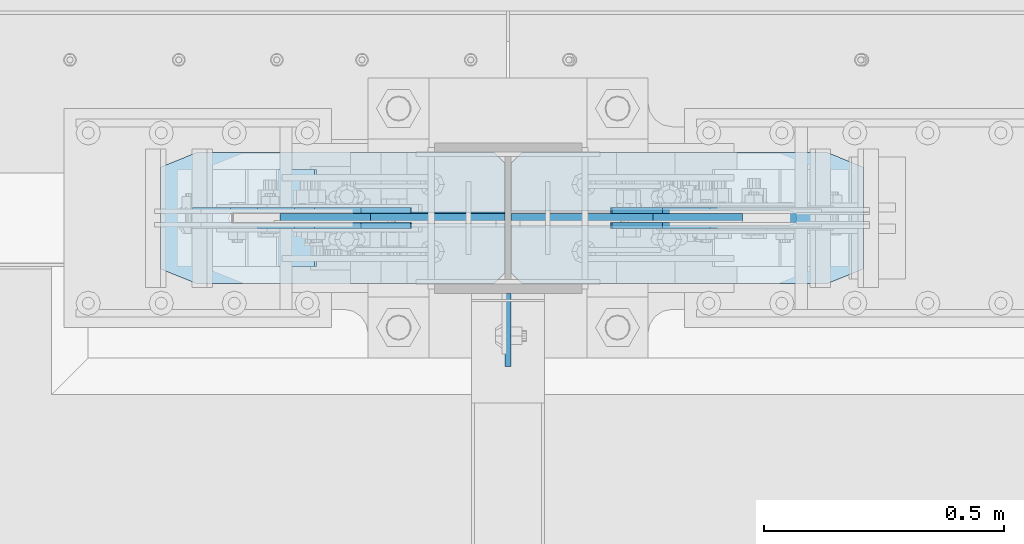
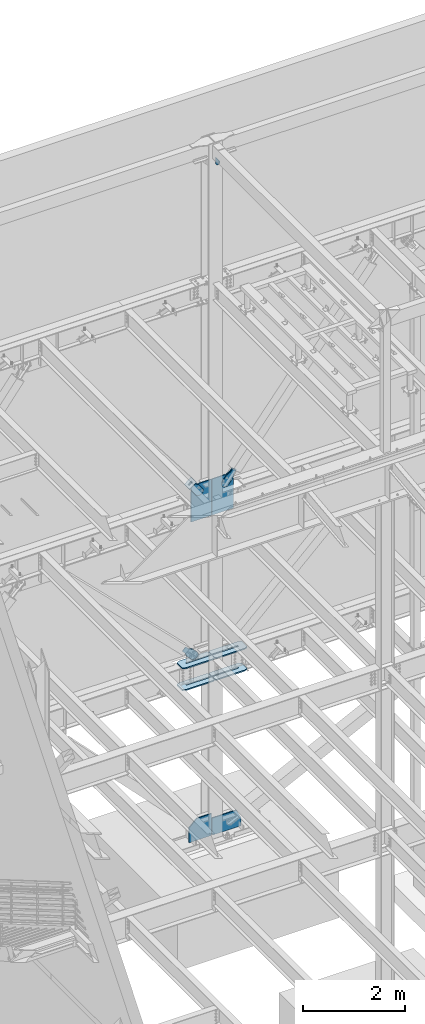
# One storey, part 1072 of 1179: 15 plates, 7 elements without a shape of their own.
"""IFC2X3 building model written with IfcOpenShell, lengths in millimetres."""

from ifc_helpers import new_model, si_unit, frame, origin_with_axes, place, context, subcontext, project, spatial, faceted_brep, material, type_object, element, aggregate, save


model = new_model("IFC2X3")

# Units and contexts
model_context = context("Model", 3, precision=1e-05, world=origin_with_axes())
body_context = subcontext(model_context, "Body", "Model", "MODEL_VIEW")
ifc_project = project(units=[si_unit("LENGTHUNIT", "METRE", prefix="MILLI"), si_unit("AREAUNIT", "SQUARE_METRE"), si_unit("VOLUMEUNIT", "CUBIC_METRE"), si_unit("MASSUNIT", "GRAM", prefix="KILO"), si_unit("TIMEUNIT", "SECOND"), si_unit("PLANEANGLEUNIT", "RADIAN"), si_unit("SOLIDANGLEUNIT", "STERADIAN"), si_unit("THERMODYNAMICTEMPERATUREUNIT", "DEGREE_CELSIUS"), si_unit("LUMINOUSINTENSITYUNIT", "LUMEN")], contexts=[model_context])

# Site, building, storey
site_placement = place(None, origin_with_axes())
site = spatial("IfcSite", under=ifc_project, at=site_placement, CompositionType="ELEMENT")
building_placement = place(site_placement, origin_with_axes())
building = spatial("IfcBuilding", under=site, at=building_placement, Name="Undefined", CompositionType="ELEMENT")
storey_placement = place(building_placement, origin_with_axes())
storey = spatial("IfcBuildingStorey", under=building, at=storey_placement, Name="Undefined", CompositionType="ELEMENT", Elevation=0.0)

# Assembly, plate
assembly_1_placement = place(storey_placement, origin_with_axes())
assembly_1 = element("IfcElementAssembly", 1, at=assembly_1_placement, inside=storey, Name="Plate", AssemblyPlace="NOTDEFINED", PredefinedType="RIGID_FRAME")
ifc_material_1 = material(Name="STEEL/A36")
plate_type_1 = type_object("IfcPlateType", PredefinedType="NOTDEFINED")
plate_1_placement = place(assembly_1_placement, frame((7716.96485451792, 41300.4, 8310.43822149673), z_axis=(0.795206441873756, 0.0, 0.606338778903742), x_axis=(0.0, -1.0, 0.0)))
plate_1 = element("IfcPlate", 2, at=plate_1_placement, type_object=plate_type_1, material=ifc_material_1, Name="Plate", context=body_context, shape_type="Brep", body=[
    faceted_brep([(0.0, -3.17500000000109, 0.0), (0.0, -3.17500000000291, 203.200000000368), (0.0, 3.17499999998836, 203.200000000361), (0.0, 3.17500000000109, 7.27595761418343e-12), (203.199999999997, -3.17500000000291, 203.200000000368), (203.199999999997, 3.17499999998836, 203.200000000361), (203.199999999997, -3.17499999999927, 3.63797880709171e-12), (203.199999999997, 3.17499999999382, -3.63797880709171e-12)], [[[0, 1, 2, 3]], [[1, 4, 5, 2]], [[4, 6, 7, 5]], [[6, 0, 3, 7]], [[5, 7, 3, 2]], [[6, 4, 1, 0]]]),
])
aggregate(assembly_1, [plate_1])

# Assembly, plates
assembly_2_placement = place(storey_placement, origin_with_axes())
assembly_2 = element("IfcElementAssembly", 3, at=assembly_2_placement, inside=storey, Name="COLUMN", AssemblyPlace="NOTDEFINED", PredefinedType="RIGID_FRAME")
ifc_material_2 = material(Name="STEEL/A572-GR.50")
plate_type_2 = type_object("IfcPlateType", PredefinedType="NOTDEFINED")
plate_2_placement = place(assembly_2_placement, frame((9022.28952609227, 41335.325, 3567.11249999999), z_axis=(0.0, -1.0, 0.0), x_axis=(-1.0, 0.0, 0.0)))
plate_2 = element("IfcPlate", 4, at=plate_2_placement, type_object=plate_type_2, material=ifc_material_2, Name="PLATE", context=body_context, shape_type="Brep", body=[
    faceted_brep([(0.0, -14.2875000000004, 30.1625003814697), (0.0, -14.2874999999999, 242.887505722043), (0.0, 14.2874999999999, 242.887505722043), (0.0, 14.2875000000004, 30.1625003814697), (74.6125030517578, -14.2874999999999, 273.050006103513), (74.6125030517578, 14.2874999999999, 273.050006103513), (713.314525710799, -14.2874999999999, 273.050006103513), (713.314525710799, 14.2874999999999, 273.050006103513), (735.539526092269, -14.2874999999999, 250.825005722043), (735.539526092269, 14.2874999999999, 250.825005722043), (735.539526092269, -14.2874999999999, 150.812499999993), (735.539526092269, 14.2874999999999, 150.812499999993), (153.987500381469, -14.2874999999999, 150.812499999993), (153.987500381469, 14.2874999999999, 150.812499999993), (148.51991069557, -14.2874999999999, 149.724928791707), (148.51991069557, 14.2874999999999, 149.724928791707), (143.884711975526, -14.2874999999999, 146.627788024467), (143.884711975526, 14.2874999999999, 146.627788024467), (140.787571208282, -14.2874999999999, 141.99258930442), (140.787571208282, 14.2874999999999, 141.99258930442), (139.699999999999, -14.2874999999999, 136.525000381465), (139.699999999999, 14.2874999999999, 136.525000381465), (140.787571208282, -14.2874999999999, 131.057410695568), (140.787571208282, 14.2874999999999, 131.057410695568), (143.884711975526, -14.2874999999999, 126.422211975521), (143.884711975526, 14.2874999999999, 126.422211975521), (148.51991069557, -14.2874999999999, 123.325071208281), (148.51991069557, 14.2874999999999, 123.325071208281), (153.987500381469, -14.2874999999999, 122.237499999996), (153.987500381469, 14.2874999999999, 122.237499999996), (735.539526092269, -14.2874999999999, 122.237499999996), (735.539526092269, 14.2874999999999, 122.237499999996), (735.539526092269, -14.2874999999999, 22.2250003814697), (735.539526092269, 14.2874999999999, 22.2250003814697), (713.314525710799, -14.2874999999999, 0.0), (713.314525710799, 14.2874999999999, 0.0), (74.6125030517578, -14.2875000000004, 0.0), (74.6125030517578, 14.2875000000004, 0.0)], [[[0, 1, 2, 3]], [[1, 4, 5, 2]], [[4, 6, 7, 5]], [[6, 8, 9, 7]], [[8, 10, 11, 9]], [[10, 12, 13, 11]], [[12, 14, 15, 13]], [[14, 16, 17, 15]], [[16, 18, 19, 17]], [[18, 20, 21, 19]], [[20, 22, 23, 21]], [[22, 24, 25, 23]], [[24, 26, 27, 25]], [[26, 28, 29, 27]], [[28, 30, 31, 29]], [[30, 32, 33, 31]], [[32, 34, 35, 33]], [[34, 36, 37, 35]], [[36, 0, 3, 37]], [[5, 7, 9, 11, 13, 15, 17, 19, 21, 23, 25, 27, 29, 31, 33, 35, 37, 3, 2]], [[36, 34, 32, 30, 28, 26, 24, 22, 20, 18, 16, 14, 12, 10, 8, 6, 4, 1, 0]]]),
])
plate_3_placement = place(assembly_2_placement, frame((9022.28952609227, 41335.325, 4087.8125), z_axis=(0.0, -1.0, 0.0), x_axis=(-1.0, 0.0, 0.0)))
plate_3 = element("IfcPlate", 5, at=plate_3_placement, type_object=plate_type_2, material=ifc_material_2, Name="PLATE", context=body_context, shape_type="Brep", body=[
    faceted_brep([(0.0, -14.2875000000004, 30.1625003814697), (0.0, -14.2874999999999, 242.887505722043), (0.0, 14.2874999999999, 242.887505722043), (0.0, 14.2875000000004, 30.1625003814697), (74.6125030517578, -14.2874999999999, 273.050006103513), (74.6125030517578, 14.2874999999999, 273.050006103513), (713.314525710799, -14.2874999999999, 273.050006103513), (713.314525710799, 14.2874999999999, 273.050006103513), (735.539526092269, -14.2874999999999, 250.825005722043), (735.539526092269, 14.2874999999999, 250.825005722043), (735.539526092269, -14.2874999999999, 150.812499999993), (735.539526092269, 14.2874999999999, 150.812499999993), (153.987500381469, -14.2874999999999, 150.812499999993), (153.987500381469, 14.2874999999999, 150.812499999993), (148.51991069557, -14.2874999999999, 149.724928791707), (148.51991069557, 14.2874999999999, 149.724928791707), (143.884711975526, -14.2874999999999, 146.627788024467), (143.884711975526, 14.2874999999999, 146.627788024467), (140.787571208282, -14.2874999999999, 141.99258930442), (140.787571208282, 14.2874999999999, 141.99258930442), (139.699999999999, -14.2874999999999, 136.525000381465), (139.699999999999, 14.2874999999999, 136.525000381465), (140.787571208282, -14.2874999999999, 131.057410695568), (140.787571208282, 14.2874999999999, 131.057410695568), (143.884711975526, -14.2874999999999, 126.422211975521), (143.884711975526, 14.2874999999999, 126.422211975521), (148.51991069557, -14.2874999999999, 123.325071208281), (148.51991069557, 14.2874999999999, 123.325071208281), (153.987500381469, -14.2874999999999, 122.237499999996), (153.987500381469, 14.2874999999999, 122.237499999996), (735.539526092269, -14.2874999999999, 122.237499999996), (735.539526092269, 14.2874999999999, 122.237499999996), (735.539526092269, -14.2874999999999, 22.2250003814697), (735.539526092269, 14.2874999999999, 22.2250003814697), (713.314525710799, -14.2874999999999, 0.0), (713.314525710799, 14.2874999999999, 0.0), (74.6125030517578, -14.2875000000004, 0.0), (74.6125030517578, 14.2875000000004, 0.0)], [[[0, 1, 2, 3]], [[1, 4, 5, 2]], [[4, 6, 7, 5]], [[6, 8, 9, 7]], [[8, 10, 11, 9]], [[10, 12, 13, 11]], [[12, 14, 15, 13]], [[14, 16, 17, 15]], [[16, 18, 19, 17]], [[18, 20, 21, 19]], [[20, 22, 23, 21]], [[22, 24, 25, 23]], [[24, 26, 27, 25]], [[26, 28, 29, 27]], [[28, 30, 31, 29]], [[30, 32, 33, 31]], [[32, 34, 35, 33]], [[34, 36, 37, 35]], [[36, 0, 3, 37]], [[5, 7, 9, 11, 13, 15, 17, 19, 21, 23, 25, 27, 29, 31, 33, 35, 37, 3, 2]], [[36, 34, 32, 30, 28, 26, 24, 22, 20, 18, 16, 14, 12, 10, 8, 6, 4, 1, 0]]]),
])
plate_4_placement = place(assembly_2_placement, frame((7555.0869148553, 41335.325, 3567.1125), z_axis=(0.0, -1.0, 0.0), x_axis=(1.0, 0.0, 0.0)))
plate_4 = element("IfcPlate", 6, at=plate_4_placement, type_object=plate_type_2, material=ifc_material_2, Name="PLATE", context=body_context, shape_type="Brep", body=[
    faceted_brep([(0.0, -14.2875000000004, 30.1625003814697), (0.0, -14.2874999999999, 242.887505722043), (0.0, 14.2874999999999, 242.887505722043), (0.0, 14.2875000000004, 30.1625003814697), (74.6125030517578, -14.2874999999999, 273.050006103513), (74.6125030517578, 14.2874999999999, 273.050006103513), (696.718152189929, -14.2874999999999, 273.050006103513), (696.718152189929, 14.2874999999999, 273.050006103513), (718.943152571399, -14.2874999999999, 250.825005722043), (718.943152571399, 14.2874999999999, 250.825005722043), (718.943152571399, -14.2874999999999, 147.637499999997), (718.943152571399, 14.2874999999999, 147.637499999997), (153.987500190735, -14.2874999999999, 147.637500000004), (153.987500190735, 14.2874999999999, 147.637500000004), (149.734930475587, -14.2874999999999, 146.791611290508), (149.734930475587, 14.2874999999999, 146.791611290508), (146.129775949929, -14.2874999999999, 144.382724050069), (146.129775949929, 14.2874999999999, 144.382724050069), (143.720888709488, -14.2874999999999, 140.777569524413), (143.720888709488, 14.2874999999999, 140.777569524413), (142.875, -14.2874999999999, 136.525000190733), (142.875, 14.2874999999999, 136.525000190733), (143.720888709488, -14.2874999999999, 132.272430475583), (143.720888709488, 14.2874999999999, 132.272430475583), (146.129775949929, -14.2874999999999, 128.667275949927), (146.129775949929, 14.2874999999999, 128.667275949927), (149.734930475587, -14.2874999999999, 126.258388709488), (149.734930475587, 14.2874999999999, 126.258388709488), (153.987500190735, -14.2874999999999, 125.412499999999), (153.987500190735, 14.2874999999999, 125.412499999999), (718.943152571399, -14.2874999999999, 125.412499999999), (718.943152571399, 14.2874999999999, 125.412499999999), (718.943152571399, -14.2874999999999, 22.2250003814697), (718.943152571399, 14.2874999999999, 22.2250003814697), (696.718152189929, -14.2874999999999, 0.0), (696.718152189929, 14.2874999999999, 0.0), (74.6125030517578, -14.2875000000004, 0.0), (74.6125030517578, 14.2875000000004, 0.0)], [[[0, 1, 2, 3]], [[1, 4, 5, 2]], [[4, 6, 7, 5]], [[6, 8, 9, 7]], [[8, 10, 11, 9]], [[10, 12, 13, 11]], [[12, 14, 15, 13]], [[14, 16, 17, 15]], [[16, 18, 19, 17]], [[18, 20, 21, 19]], [[20, 22, 23, 21]], [[22, 24, 25, 23]], [[24, 26, 27, 25]], [[26, 28, 29, 27]], [[28, 30, 31, 29]], [[30, 32, 33, 31]], [[32, 34, 35, 33]], [[34, 36, 37, 35]], [[36, 0, 3, 37]], [[5, 7, 9, 11, 13, 15, 17, 19, 21, 23, 25, 27, 29, 31, 33, 35, 37, 3, 2]], [[36, 34, 32, 30, 28, 26, 24, 22, 20, 18, 16, 14, 12, 10, 8, 6, 4, 1, 0]]]),
])
plate_5_placement = place(assembly_2_placement, frame((7555.0869148553, 41335.325, 4087.8125), z_axis=(0.0, -1.0, 0.0), x_axis=(1.0, 0.0, 0.0)))
plate_5 = element("IfcPlate", 7, at=plate_5_placement, type_object=plate_type_2, material=ifc_material_2, Name="PLATE", context=body_context, shape_type="Brep", body=[
    faceted_brep([(0.0, -14.2875000000004, 30.1625003814697), (0.0, -14.2874999999999, 242.887505722043), (0.0, 14.2874999999999, 242.887505722043), (0.0, 14.2875000000004, 30.1625003814697), (74.6125030517578, -14.2874999999999, 273.050006103513), (74.6125030517578, 14.2874999999999, 273.050006103513), (696.718152189929, -14.2874999999999, 273.050006103513), (696.718152189929, 14.2874999999999, 273.050006103513), (718.943152571399, -14.2874999999999, 250.825005722043), (718.943152571399, 14.2874999999999, 250.825005722043), (718.943152571399, -14.2874999999999, 147.637499999997), (718.943152571399, 14.2874999999999, 147.637499999997), (153.987500190735, -14.2874999999999, 147.637500000004), (153.987500190735, 14.2874999999999, 147.637500000004), (149.734930475587, -14.2874999999999, 146.791611290508), (149.734930475587, 14.2874999999999, 146.791611290508), (146.129775949929, -14.2874999999999, 144.382724050069), (146.129775949929, 14.2874999999999, 144.382724050069), (143.720888709488, -14.2874999999999, 140.777569524413), (143.720888709488, 14.2874999999999, 140.777569524413), (142.875, -14.2874999999999, 136.525000190733), (142.875, 14.2874999999999, 136.525000190733), (143.720888709488, -14.2874999999999, 132.272430475583), (143.720888709488, 14.2874999999999, 132.272430475583), (146.129775949929, -14.2874999999999, 128.667275949927), (146.129775949929, 14.2874999999999, 128.667275949927), (149.734930475587, -14.2874999999999, 126.258388709488), (149.734930475587, 14.2874999999999, 126.258388709488), (153.987500190735, -14.2874999999999, 125.412499999999), (153.987500190735, 14.2874999999999, 125.412499999999), (718.943152571399, -14.2874999999999, 125.412499999999), (718.943152571399, 14.2874999999999, 125.412499999999), (718.943152571399, -14.2874999999999, 22.2250003814697), (718.943152571399, 14.2874999999999, 22.2250003814697), (696.718152189929, -14.2874999999999, 0.0), (696.718152189929, 14.2874999999999, 0.0), (74.6125030517578, -14.2875000000004, 0.0), (74.6125030517578, 14.2875000000004, 0.0)], [[[0, 1, 2, 3]], [[1, 4, 5, 2]], [[4, 6, 7, 5]], [[6, 8, 9, 7]], [[8, 10, 11, 9]], [[10, 12, 13, 11]], [[12, 14, 15, 13]], [[14, 16, 17, 15]], [[16, 18, 19, 17]], [[18, 20, 21, 19]], [[20, 22, 23, 21]], [[22, 24, 25, 23]], [[24, 26, 27, 25]], [[26, 28, 29, 27]], [[28, 30, 31, 29]], [[30, 32, 33, 31]], [[32, 34, 35, 33]], [[34, 36, 37, 35]], [[36, 0, 3, 37]], [[5, 7, 9, 11, 13, 15, 17, 19, 21, 23, 25, 27, 29, 31, 33, 35, 37, 3, 2]], [[36, 34, 32, 30, 28, 26, 24, 22, 20, 18, 16, 14, 12, 10, 8, 6, 4, 1, 0]]]),
])
plate_type_3 = type_object("IfcPlateType", PredefinedType="NOTDEFINED")
plate_6_placement = place(assembly_2_placement, frame((8280.4, 40889.2375061035, 16109.95), z_axis=(0.0, 1.0, 0.0), x_axis=(0.0, 0.0, -1.0)))
plate_6 = element("IfcPlate", 8, at=plate_6_placement, type_object=plate_type_3, material=ifc_material_1, Name="PLATE", context=body_context, shape_type="Brep", body=[
    faceted_brep([(0.0, -6.34999999999854, 0.0), (0.0, -6.34999999999854, 152.400000000001), (0.0, 6.34999999999854, 152.400000000001), (0.0, 6.34999999999854, 0.0), (152.399993896484, -6.34999999999854, 152.399993896484), (152.399993896484, 6.34999999999854, 152.399993896484), (152.399993896484, -6.34999999999854, 88.6901931762695), (152.399993896484, 6.34999999999854, 88.6901931762695), (63.5, -6.34999999999854, 0.0), (63.5, 6.34999999999854, 0.0)], [[[0, 1, 2, 3]], [[1, 4, 5, 2]], [[4, 6, 7, 5]], [[6, 8, 9, 7]], [[8, 0, 3, 9]], [[5, 7, 9, 3, 2]], [[8, 6, 4, 1, 0]]]),
])
plate_type_4 = type_object("IfcPlateType", PredefinedType="NOTDEFINED")
plate_7_placement = place(assembly_2_placement, frame((8286.75, 41198.8, 7445.375), z_axis=(0.0, 0.0, 1.0), x_axis=(1.0, 0.0, 0.0)))
plate_7 = element("IfcPlate", 9, at=plate_7_placement, type_object=plate_type_4, material=ifc_material_2, Name="PLATE", context=body_context, shape_type="Brep", body=[
    faceted_brep([(0.0, -9.52499999999964, 0.0), (0.0, -9.52500000000146, 866.173326861562), (0.0, 9.52500000000146, 866.173326861562), (0.0, 9.52499999999964, 0.0), (296.459325144328, -9.52500000000146, 866.173326861562), (296.459325144328, 9.52500000000146, 866.173326861562), (482.896403209315, -9.52500000000146, 718.035784193981), (482.896403209315, 9.52500000000146, 718.035784193981), (482.896403209315, -9.52500000000146, 0.0), (482.896403209315, 9.52500000000146, 0.0)], [[[0, 1, 2, 3]], [[1, 4, 5, 2]], [[4, 6, 7, 5]], [[6, 8, 9, 7]], [[8, 0, 3, 9]], [[5, 7, 9, 3, 2]], [[8, 6, 4, 1, 0]]]),
])

# Assembly, plate
assembly_3_placement = place(storey_placement, origin_with_axes())
assembly_3 = element("IfcElementAssembly", 10, at=assembly_3_placement, inside=storey, AssemblyPlace="NOTDEFINED", PredefinedType="RIGID_FRAME")
plate_type_5 = type_object("IfcPlateType", PredefinedType="NOTDEFINED")
plate_8_placement = place(assembly_3_placement, frame((8777.66583684643, 41214.675, 8286.80641475323), z_axis=(-0.782937860640372, 0.0, 0.62209991671425), x_axis=(0.622099916714251, 0.0, 0.782937860640372)))
plate_8 = element("IfcPlate", 11, at=plate_8_placement, type_object=plate_type_5, material=ifc_material_1, context=body_context, shape_type="Brep", body=[
    faceted_brep([(0.0, -6.34999999999854, 0.0), (-101.600000000007, -6.34999999999854, -45.085691726028), (-101.600000000007, 6.34999999999854, -45.085691726028), (0.0, 6.34999999999854, 0.0), (-245.369242322517, -6.34999999999854, -45.085691725908), (-245.369242322517, 6.34999999999854, -45.085691725908), (-281.212328722571, -6.34999999999854, -37.9560585558283), (-281.212328722571, 6.34999999999854, -37.9560585558283), (-311.598630136563, -6.34999999999854, -17.6525810655148), (-311.598630136563, 6.34999999999854, -17.6525810655148), (-331.902107626699, -6.34999999999854, 12.7337203485949), (-331.902107626699, 6.34999999999854, 12.7337203485949), (-339.031740796561, -6.34999999999854, 48.5768098006738), (-339.031740796561, 6.34999999999854, 48.5768098006738), (-331.902107626408, -6.34999999999854, 84.4198962005139), (-331.902107626408, 6.34999999999854, 84.4198962005139), (-311.598630136172, -6.34999999999854, 114.806197614322), (-311.598630136172, 6.34999999999854, 114.806197614322), (-281.212328722244, -6.34999999999854, 135.109675104381), (-281.212328722244, 6.34999999999854, 135.109675104381), (-245.369240796288, -6.34999999999854, 142.239308274318), (-245.369240796288, 6.34999999999854, 142.239308274318), (-101.599999999052, -6.34999999999854, 142.239308274202), (-101.599999999052, 6.34999999999854, 142.239308274202), (4.938556230627e-10, -6.34999999999854, 97.1536165479993), (4.938556230627e-10, 6.34999999999854, 97.1536165479993), (82.5500000003167, -6.34999999999854, 97.1536165479301), (82.5500000003167, 6.34999999999854, 97.1536165479301), (82.550000000203, -6.34999999999854, 1.2732925824821e-10), (82.550000000203, 6.34999999999854, 1.2732925824821e-10)], [[[0, 1, 2, 3]], [[1, 4, 5, 2]], [[4, 6, 7, 5]], [[6, 8, 9, 7]], [[8, 10, 11, 9]], [[10, 12, 13, 11]], [[12, 14, 15, 13]], [[14, 16, 17, 15]], [[16, 18, 19, 17]], [[18, 20, 21, 19]], [[20, 22, 23, 21]], [[22, 24, 25, 23]], [[24, 26, 27, 25]], [[26, 28, 29, 27]], [[28, 0, 3, 29]], [[5, 7, 9, 11, 13, 15, 17, 19, 21, 23, 25, 27, 29, 3, 2]], [[28, 26, 24, 22, 20, 18, 16, 14, 12, 10, 8, 6, 4, 1, 0]]]),
])
aggregate(assembly_3, [plate_8])

assembly_4_placement = place(storey_placement, origin_with_axes())
assembly_4 = element("IfcElementAssembly", 12, at=assembly_4_placement, inside=storey, AssemblyPlace="NOTDEFINED", PredefinedType="RIGID_FRAME")
plate_9_placement = place(assembly_4_placement, frame((8777.66583684643, 41182.925, 8286.80641475323), z_axis=(-0.782937860640372, 0.0, 0.62209991671425), x_axis=(0.622099916714251, 0.0, 0.782937860640372)))
plate_9 = element("IfcPlate", 13, at=plate_9_placement, type_object=plate_type_5, material=ifc_material_1, context=body_context, shape_type="Brep", body=[
    faceted_brep([(0.0, -6.34999999999854, 0.0), (-101.600000000007, -6.34999999999854, -45.085691726028), (-101.600000000007, 6.34999999999854, -45.085691726028), (0.0, 6.34999999999854, 0.0), (-245.369242322517, -6.34999999999854, -45.085691725908), (-245.369242322517, 6.34999999999854, -45.085691725908), (-281.212328722571, -6.34999999999854, -37.9560585558283), (-281.212328722571, 6.34999999999854, -37.9560585558283), (-311.598630136563, -6.34999999999854, -17.6525810655148), (-311.598630136563, 6.34999999999854, -17.6525810655148), (-331.902107626699, -6.34999999999854, 12.7337203485949), (-331.902107626699, 6.34999999999854, 12.7337203485949), (-339.031740796561, -6.34999999999854, 48.5768098006738), (-339.031740796561, 6.34999999999854, 48.5768098006738), (-331.902107626408, -6.34999999999854, 84.4198962005139), (-331.902107626408, 6.34999999999854, 84.4198962005139), (-311.598630136172, -6.34999999999854, 114.806197614322), (-311.598630136172, 6.34999999999854, 114.806197614322), (-281.212328722244, -6.34999999999854, 135.109675104381), (-281.212328722244, 6.34999999999854, 135.109675104381), (-245.369240796288, -6.34999999999854, 142.239308274318), (-245.369240796288, 6.34999999999854, 142.239308274318), (-101.599999999052, -6.34999999999854, 142.239308274202), (-101.599999999052, 6.34999999999854, 142.239308274202), (4.938556230627e-10, -6.34999999999854, 97.1536165479993), (4.938556230627e-10, 6.34999999999854, 97.1536165479993), (82.5500000003167, -6.34999999999854, 97.1536165479301), (82.5500000003167, 6.34999999999854, 97.1536165479301), (82.550000000203, -6.34999999999854, 1.2732925824821e-10), (82.550000000203, 6.34999999999854, 1.2732925824821e-10)], [[[0, 1, 2, 3]], [[1, 4, 5, 2]], [[4, 6, 7, 5]], [[6, 8, 9, 7]], [[8, 10, 11, 9]], [[10, 12, 13, 11]], [[12, 14, 15, 13]], [[14, 16, 17, 15]], [[16, 18, 19, 17]], [[18, 20, 21, 19]], [[20, 22, 23, 21]], [[22, 24, 25, 23]], [[24, 26, 27, 25]], [[26, 28, 29, 27]], [[28, 0, 3, 29]], [[5, 7, 9, 11, 13, 15, 17, 19, 21, 23, 25, 27, 29, 3, 2]], [[28, 26, 24, 22, 20, 18, 16, 14, 12, 10, 8, 6, 4, 1, 0]]]),
])
aggregate(assembly_4, [plate_9])

assembly_5_placement = place(storey_placement, origin_with_axes())
assembly_5 = element("IfcElementAssembly", 14, at=assembly_5_placement, inside=storey, AssemblyPlace="NOTDEFINED", PredefinedType="RIGID_FRAME")
plate_10_placement = place(assembly_5_placement, frame((7834.46129425382, 41214.675, 8404.02102449742), z_axis=(-0.795206441873757, 0.0, -0.60633877890374), x_axis=(0.60633877890374, 0.0, -0.795206441873757)))
plate_10 = element("IfcPlate", 15, at=plate_10_placement, type_object=plate_type_5, material=ifc_material_1, context=body_context, shape_type="Brep", body=[
    faceted_brep([(0.0, -6.34999999999854, 0.0), (4.938556230627e-10, -6.34999999999854, 97.1536165479993), (4.938556230627e-10, 6.34999999999854, 97.1536165479993), (0.0, 6.34999999999854, 0.0), (68.5800000003655, -6.34999999999854, 97.153616547841), (68.5800000003655, 6.34999999999854, 97.153616547841), (170.180000000595, -6.34999999999854, 142.239308273867), (170.180000000595, 6.34999999999854, 142.239308273867), (313.949242323917, -6.34999999999854, 142.239308273847), (313.949242323917, 6.34999999999854, 142.239308273847), (349.792328723946, -6.34999999999854, 135.109675103793), (349.792328723946, 6.34999999999854, 135.109675103793), (380.178630137938, -6.34999999999854, 114.80619761351), (380.178630137938, 6.34999999999854, 114.80619761351), (400.482107628101, -6.34999999999854, 84.4198961994261), (400.482107628101, 6.34999999999854, 84.4198961994261), (407.611740798023, -6.34999999999854, 48.5768067476838), (407.611740798023, 6.34999999999854, 48.5768067476838), (400.482107627932, -6.34999999999854, 12.7337203478164), (400.482107627932, 6.34999999999854, 12.7337203478164), (380.178630137746, -6.34999999999854, -17.6525810660296), (380.178630137746, 6.34999999999854, -17.6525810660296), (349.79232872385, -6.34999999999854, -37.9560585561248), (349.79232872385, 6.34999999999854, -37.9560585561248), (313.949240797645, -6.34999999999854, -45.085691726099), (313.949240797645, 6.34999999999854, -45.085691726099), (170.17999999998, -6.34999999999854, -45.0856917260735), (170.17999999998, 6.34999999999854, -45.0856917260735), (68.5800000000518, -6.34999999999854, -9.09494701772928e-12), (68.5800000000518, 6.34999999999854, -9.09494701772928e-12)], [[[0, 1, 2, 3]], [[1, 4, 5, 2]], [[4, 6, 7, 5]], [[6, 8, 9, 7]], [[8, 10, 11, 9]], [[10, 12, 13, 11]], [[12, 14, 15, 13]], [[14, 16, 17, 15]], [[16, 18, 19, 17]], [[18, 20, 21, 19]], [[20, 22, 23, 21]], [[22, 24, 25, 23]], [[24, 26, 27, 25]], [[26, 28, 29, 27]], [[28, 0, 3, 29]], [[5, 7, 9, 11, 13, 15, 17, 19, 21, 23, 25, 27, 29, 3, 2]], [[28, 26, 24, 22, 20, 18, 16, 14, 12, 10, 8, 6, 4, 1, 0]]]),
])
aggregate(assembly_5, [plate_10])

assembly_6_placement = place(storey_placement, origin_with_axes())
assembly_6 = element("IfcElementAssembly", 16, at=assembly_6_placement, inside=storey, AssemblyPlace="NOTDEFINED", PredefinedType="RIGID_FRAME")
plate_11_placement = place(assembly_6_placement, frame((7834.46129425382, 41182.925, 8404.02102449742), z_axis=(-0.795206441873757, 0.0, -0.60633877890374), x_axis=(0.60633877890374, 0.0, -0.795206441873757)))
plate_11 = element("IfcPlate", 17, at=plate_11_placement, type_object=plate_type_5, material=ifc_material_1, context=body_context, shape_type="Brep", body=[
    faceted_brep([(0.0, -6.34999999999854, 0.0), (4.938556230627e-10, -6.34999999999854, 97.1536165479993), (4.938556230627e-10, 6.34999999999854, 97.1536165479993), (0.0, 6.34999999999854, 0.0), (68.5800000003655, -6.34999999999854, 97.153616547841), (68.5800000003655, 6.34999999999854, 97.153616547841), (170.180000000595, -6.34999999999854, 142.239308273867), (170.180000000595, 6.34999999999854, 142.239308273867), (313.949242323917, -6.34999999999854, 142.239308273847), (313.949242323917, 6.34999999999854, 142.239308273847), (349.792328723946, -6.34999999999854, 135.109675103793), (349.792328723946, 6.34999999999854, 135.109675103793), (380.178630137938, -6.34999999999854, 114.80619761351), (380.178630137938, 6.34999999999854, 114.80619761351), (400.482107628101, -6.34999999999854, 84.4198961994261), (400.482107628101, 6.34999999999854, 84.4198961994261), (407.611740798023, -6.34999999999854, 48.5768067476838), (407.611740798023, 6.34999999999854, 48.5768067476838), (400.482107627932, -6.34999999999854, 12.7337203478164), (400.482107627932, 6.34999999999854, 12.7337203478164), (380.178630137746, -6.34999999999854, -17.6525810660296), (380.178630137746, 6.34999999999854, -17.6525810660296), (349.79232872385, -6.34999999999854, -37.9560585561248), (349.79232872385, 6.34999999999854, -37.9560585561248), (313.949240797645, -6.34999999999854, -45.085691726099), (313.949240797645, 6.34999999999854, -45.085691726099), (170.17999999998, -6.34999999999854, -45.0856917260735), (170.17999999998, 6.34999999999854, -45.0856917260735), (68.5800000000518, -6.34999999999854, -9.09494701772928e-12), (68.5800000000518, 6.34999999999854, -9.09494701772928e-12)], [[[0, 1, 2, 3]], [[1, 4, 5, 2]], [[4, 6, 7, 5]], [[6, 8, 9, 7]], [[8, 10, 11, 9]], [[10, 12, 13, 11]], [[12, 14, 15, 13]], [[14, 16, 17, 15]], [[16, 18, 19, 17]], [[18, 20, 21, 19]], [[20, 22, 23, 21]], [[22, 24, 25, 23]], [[24, 26, 27, 25]], [[26, 28, 29, 27]], [[28, 0, 3, 29]], [[5, 7, 9, 11, 13, 15, 17, 19, 21, 23, 25, 27, 29, 3, 2]], [[28, 26, 24, 22, 20, 18, 16, 14, 12, 10, 8, 6, 4, 1, 0]]]),
])
aggregate(assembly_6, [plate_11])

assembly_7_placement = place(storey_placement, origin_with_axes())
assembly_7 = element("IfcElementAssembly", 18, at=assembly_7_placement, inside=storey, AssemblyPlace="NOTDEFINED", PredefinedType="RIGID_FRAME")
plate_12_placement = place(assembly_7_placement, frame((7700.73462762327, 41214.675, 4484.45040012886), z_axis=(-0.705959813968941, 0.0, -0.708251890968841), x_axis=(0.708251890968839, 0.0, -0.705959813968942)))
plate_12 = element("IfcPlate", 19, at=plate_12_placement, type_object=plate_type_5, material=ifc_material_1, context=body_context, shape_type="Brep", body=[
    faceted_brep([(0.0, -6.34999999999854, 0.0), (-4.35647962149233e-10, -6.34999999999854, 112.184930806416), (-4.35647962149233e-10, 6.34999999999854, 112.184930806416), (0.0, 6.34999999999854, 0.0), (82.5499999996491, -6.34999999999854, 112.184930806461), (82.5499999996491, 6.34999999999854, 112.184930806461), (184.149999999618, -6.34999999999854, 149.75496540347), (184.149999999618, 6.34999999999854, 149.75496540347), (327.919242323534, -6.34999999999854, 149.754965403559), (327.919242323534, 6.34999999999854, 149.754965403559), (363.762328723451, -6.34999999999854, 142.625332233587), (363.762328723451, 6.34999999999854, 142.625332233587), (394.148630137406, -6.34999999999854, 122.321854743475), (394.148630137406, 6.34999999999854, 122.321854743475), (414.452107627645, -6.34999999999854, 91.9355533295929), (414.452107627645, 6.34999999999854, 91.9355533295929), (421.581740797776, -6.34999999999854, 56.0924638777396), (421.581740797776, 6.34999999999854, 56.0924638777396), (414.452107627878, -6.34999999999854, 20.2493774776722), (414.452107627878, 6.34999999999854, 20.2493774776722), (394.14863013775, -6.34999999999854, -10.1369239363994), (394.14863013775, 6.34999999999854, -10.1369239363994), (363.762328723789, -6.34999999999854, -30.4404014266784), (363.762328723789, 6.34999999999854, -30.4404014266784), (327.919240798041, -6.34999999999854, -37.570034596738), (327.919240798041, 6.34999999999854, -37.570034596738), (184.150000000338, -6.34999999999854, -37.5700345968289), (184.150000000338, 6.34999999999854, -37.5700345968289), (82.550000000203, -6.34999999999854, 1.2732925824821e-10), (82.550000000203, 6.34999999999854, 1.2732925824821e-10)], [[[0, 1, 2, 3]], [[1, 4, 5, 2]], [[4, 6, 7, 5]], [[6, 8, 9, 7]], [[8, 10, 11, 9]], [[10, 12, 13, 11]], [[12, 14, 15, 13]], [[14, 16, 17, 15]], [[16, 18, 19, 17]], [[18, 20, 21, 19]], [[20, 22, 23, 21]], [[22, 24, 25, 23]], [[24, 26, 27, 25]], [[26, 28, 29, 27]], [[28, 0, 3, 29]], [[5, 7, 9, 11, 13, 15, 17, 19, 21, 23, 25, 27, 29, 3, 2]], [[28, 26, 24, 22, 20, 18, 16, 14, 12, 10, 8, 6, 4, 1, 0]]]),
])
aggregate(assembly_7, [plate_12])

# Plate
plate_type_6 = type_object("IfcPlateType", PredefinedType="NOTDEFINED")
plate_13_placement = place(assembly_2_placement, frame((8286.75, 41198.8, -215.9), z_axis=(0.0, 0.0, 1.0), x_axis=(1.0, 0.0, 0.0)))
plate_13 = element("IfcPlate", 20, at=plate_13_placement, type_object=plate_type_6, material=ifc_material_2, Name="PLATE", context=body_context, shape_type="Brep", body=[
    faceted_brep([(0.0, -12.7000000000007, 19.0500000000029), (0.0, -12.6999999999971, 410.442984862932), (0.0, 12.6999999999971, 410.442984862932), (0.0, 12.7000000000007, 19.0500000000029), (548.058654522602, -12.6999999999971, 410.442984862932), (548.058654522602, 12.6999999999971, 410.442984862932), (656.403200803466, -12.6999999999971, 191.286682384099), (656.403200803466, 12.6999999999971, 191.286682384099), (656.403200803466, -12.6999999999971, 0.0), (656.403200803466, 12.6999999999971, 0.0), (19.0499992370605, -12.6999999999971, 0.0), (19.0499992370605, 12.6999999999971, 0.0)], [[[0, 1, 2, 3]], [[1, 4, 5, 2]], [[4, 6, 7, 5]], [[6, 8, 9, 7]], [[8, 10, 11, 9]], [[10, 0, 3, 11]], [[5, 7, 9, 11, 3, 2]], [[10, 8, 6, 4, 1, 0]]]),
])

plate_type_7 = type_object("IfcPlateType", PredefinedType="NOTDEFINED")
plate_14_placement = place(assembly_2_placement, frame((8274.04999998553, 41198.8, 7445.375), z_axis=(0.0, 0.0, 1.0), x_axis=(-1.0, 0.0, 0.0)))
plate_14 = element("IfcPlate", 21, at=plate_14_placement, type_object=plate_type_7, material=ifc_material_2, Name="PLATE", context=body_context, shape_type="Brep", body=[
    faceted_brep([(0.0, -9.52499999999964, 0.0), (0.0, -9.52500000000146, 866.056000469541), (0.0, 9.52500000000146, 866.056000469541), (0.0, 9.52499999999964, 0.0), (280.351296218061, -9.52500000000146, 866.056000469541), (280.351296218061, 9.52500000000146, 866.056000469541), (469.70983018925, -9.52500000000146, 721.671578743088), (469.70983018925, 9.52500000000146, 721.671578743088), (469.70983100647, -9.52500000000146, 0.0), (469.70983100647, 9.52500000000146, 0.0)], [[[0, 1, 2, 3]], [[1, 4, 5, 2]], [[4, 6, 7, 5]], [[6, 8, 9, 7]], [[8, 0, 3, 9]], [[5, 7, 9, 3, 2]], [[8, 6, 4, 1, 0]]]),
])

plate_type_8 = type_object("IfcPlateType", PredefinedType="NOTDEFINED")
plate_15_placement = place(assembly_2_placement, frame((8274.05, 41198.8, -215.9), z_axis=(0.0, 0.0, 1.0), x_axis=(-1.0, 0.0, 0.0)))
plate_15 = element("IfcPlate", 22, at=plate_15_placement, type_object=plate_type_8, material=ifc_material_2, Name="PLATE", context=body_context, shape_type="Brep", body=[
    faceted_brep([(0.0, -12.7000000000007, 19.0500000000029), (0.0, -12.6999999999971, 524.798143425219), (0.0, 12.6999999999971, 524.798143425219), (0.0, 12.7000000000007, 19.0500000000029), (334.863236503119, -12.6999999999971, 524.798143425219), (334.863236503119, 12.6999999999971, 524.798143425219), (508.01845540265, -12.6999999999971, 356.741723827944), (508.01845540265, 12.6999999999971, 356.741723827944), (508.018455402651, -12.6999999999971, 0.0), (508.018455402651, 12.6999999999971, 0.0), (19.0499992370605, -12.6999999999971, 0.0), (19.0499992370605, 12.6999999999971, 0.0)], [[[0, 1, 2, 3]], [[1, 4, 5, 2]], [[4, 6, 7, 5]], [[6, 8, 9, 7]], [[8, 10, 11, 9]], [[10, 0, 3, 11]], [[5, 7, 9, 11, 3, 2]], [[10, 8, 6, 4, 1, 0]]]),
])

aggregate(assembly_2, [plate_6, plate_2, plate_3, plate_4, plate_5, plate_7, plate_13, plate_14, plate_15])

save(model, "model.ifc")
